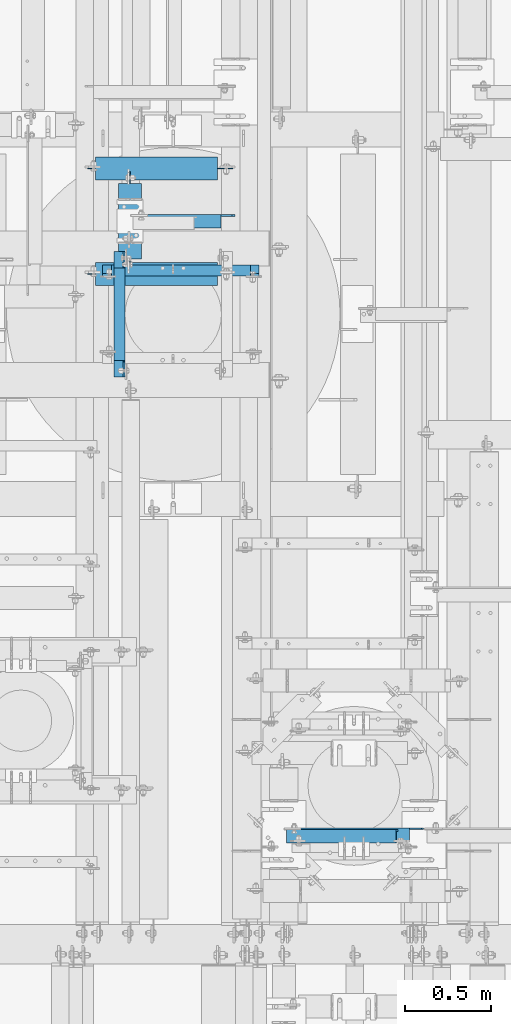
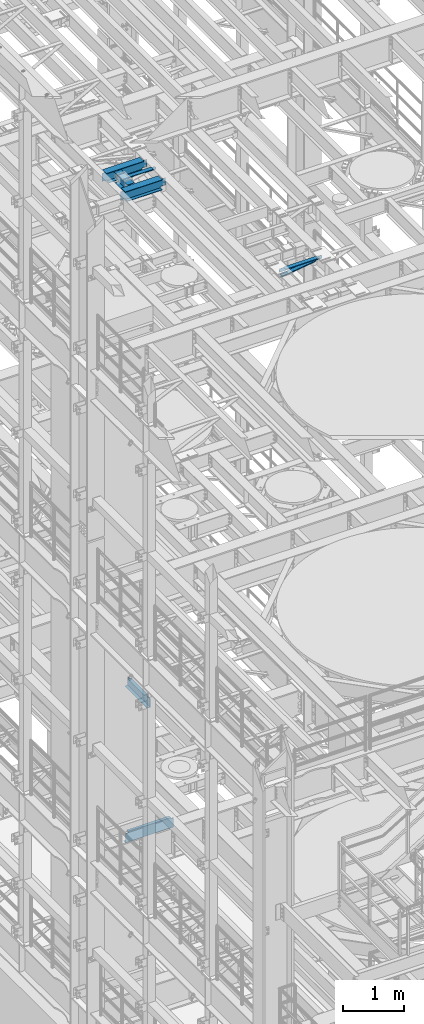
# One storey, part 1258 of 1876: 8 beams, 8 elements without a shape of their own.
"""IFC2X3 building model written with IfcOpenShell, lengths in millimetres."""

from ifc_helpers import new_model, si_unit, frame, origin_with_axes, place, context, subcontext, project, spatial, faceted_brep, material, type_object, element, aggregate, save


model = new_model("IFC2X3")

# Units and contexts
model_context = context("Model", 3, precision=1e-05, world=origin_with_axes())
body_context = subcontext(model_context, "Body", "Model", "MODEL_VIEW")
ifc_project = project(units=[si_unit("LENGTHUNIT", "METRE", prefix="MILLI"), si_unit("AREAUNIT", "SQUARE_METRE"), si_unit("VOLUMEUNIT", "CUBIC_METRE"), si_unit("MASSUNIT", "GRAM", prefix="KILO"), si_unit("TIMEUNIT", "SECOND"), si_unit("PLANEANGLEUNIT", "RADIAN"), si_unit("SOLIDANGLEUNIT", "STERADIAN"), si_unit("THERMODYNAMICTEMPERATUREUNIT", "DEGREE_CELSIUS"), si_unit("LUMINOUSINTENSITYUNIT", "LUMEN")], contexts=[model_context])

# Site, building, storey
site_placement = place(None, origin_with_axes())
site = spatial("IfcSite", under=ifc_project, at=site_placement, CompositionType="ELEMENT")
building_placement = place(site_placement, origin_with_axes())
building = spatial("IfcBuilding", under=site, at=building_placement, Name="Undefined", CompositionType="ELEMENT")
storey_placement = place(building_placement, origin_with_axes())
storey = spatial("IfcBuildingStorey", under=building, at=storey_placement, Name="Undefined", CompositionType="ELEMENT", Elevation=0.0)

# Assembly, beam
assembly_1_placement = place(storey_placement, origin_with_axes())
assembly_1 = element("IfcElementAssembly", 1, at=assembly_1_placement, inside=storey, AssemblyPlace="NOTDEFINED", PredefinedType="RIGID_FRAME")
ifc_material_1 = material(Name="STEEL/A36")
beam_type_1 = type_object("IfcBeamType", Name="L3X3X3/8", PredefinedType="NOTDEFINED")
beam_1_placement = place(assembly_1_placement, frame((4018.36120549084, 2149.47745692088, 17834.3261676342), z_axis=(0.0, -1.0, 0.0), x_axis=(0.990783001765335, -1.02999998879822e-07, 0.13545864096787)))
beam_1 = element("IfcBeam", 2, at=beam_1_placement, type_object=beam_type_1, material=ifc_material_1, ObjectType="L3X3X3/8", context=body_context, shape_type="Brep", body=[
    faceted_brep([(16.0226810146332, 38.0999999999585, -38.1000000000004), (16.0226810114837, 38.1000000000822, 38.1000000000004), (656.288881702969, 38.1000000006679, 38.0999999998849), (656.288881706117, 38.1000000005479, -38.1000000001154), (16.0226810114755, 28.5750000000808, 38.0999999999995), (656.28888170296, 28.5750000006665, 38.0999999998844), (16.0226810142303, 28.5749999999753, -28.5750000000012), (656.288881705715, 28.5750000005573, -28.5750000001158), (16.0226810141694, -38.1000000000386, -28.5750000000062), (656.288881705656, -38.0999999994565, -28.5750000001217), (16.0226810145641, -38.1000000000531, -38.1000000000063), (656.288881706049, -38.099999999471, -38.1000000001218)], [[[0, 1, 2, 3]], [[1, 4, 5, 2]], [[4, 6, 7, 5]], [[6, 8, 9, 7]], [[8, 10, 11, 9]], [[10, 0, 3, 11]], [[5, 7, 9, 11, 3, 2]], [[10, 8, 6, 4, 1, 0]]]),
])
aggregate(assembly_1, [beam_1])

assembly_2_placement = place(storey_placement, origin_with_axes())
assembly_2 = element("IfcElementAssembly", 3, at=assembly_2_placement, inside=storey, Name="ANGLE", AssemblyPlace="NOTDEFINED", PredefinedType="RIGID_FRAME")
beam_2_placement = place(assembly_2_placement, frame((4013.20024389053, 2159.00245745755, 17945.1), z_axis=(0.0, -1.0, 0.0), x_axis=(1.0, 0.0, 0.0)))
beam_2 = element("IfcBeam", 4, at=beam_2_placement, type_object=beam_type_1, material=ifc_material_1, Name="ANGLE", ObjectType="L3X3X3/8", context=body_context, shape_type="Brep", body=[
    faceted_brep([(728.662753137652, 28.5750000000007, -28.5750000001394), (728.662760071853, 28.5750000000007, 38.0999999998608), (84.1369379238226, 28.5750017223108, 38.099999999984), (84.1369309896222, 28.5750000000007, -28.5750000000166), (728.662385083913, 38.0999999999985, 38.0999999998608), (84.1373129237786, 38.0999999999985, 38.0999999999835), (15.8749292730308, 28.5750000000007, -28.5750000000035), (15.874928282431, 28.5750108662178, -38.1000000000035), (3.17492847316589, 15.8750110569526, -38.1000000000013), (3.17492946376569, 15.8750099139615, -28.5750000000012), (84.1369299990224, 28.5750108662141, -38.1000000000167), (84.1373049986182, 38.0999999999985, -38.1000000000167), (728.662377158752, 38.0999999999985, -38.1000000001395), (728.662752147051, 28.5750017223108, -38.1000000001395), (796.924754869784, 28.5750000000007, -28.5750000001522), (796.924753879185, 28.5750017223145, -38.1000000001522), (809.624754679051, 15.8750030560368, -28.5750000001544), (809.624753688451, 15.8750019130493, -38.1000000001545), (809.624754679051, 3.17500420044598, -28.5750000001544), (809.624753688451, 3.17500305745853, -38.1000000001545), (809.62475315317, -38.0999999999985, -28.5750000001549), (809.62475216257, -38.0999999999985, -38.100000000155), (3.17493098964678, -38.0999999999985, -28.5750000000012), (3.17492999904698, -38.0999999999985, -38.1000000000013), (3.17492847316589, 3.17501220136182, -38.1000000000013), (3.17492946376569, 3.17501105837073, -28.5750000000012)], [[[0, 1, 2, 3]], [[1, 4, 5, 2]], [[6, 7, 8, 9]], [[3, 10, 7, 6]], [[2, 5, 11, 10, 3]], [[4, 12, 11, 5]], [[1, 0, 13, 12, 4]], [[14, 15, 13, 0]], [[16, 17, 15, 14]], [[18, 19, 17, 16]], [[19, 18, 20, 21]], [[21, 20, 22, 23]], [[8, 7, 10, 11, 12, 13, 15, 17, 19, 21, 23, 24]], [[9, 8, 24, 25]], [[20, 18, 16, 14, 0, 3, 6, 9, 25, 22]], [[24, 23, 22, 25]]]),
])
aggregate(assembly_2, [beam_2])

assembly_3_placement = place(storey_placement, origin_with_axes())
assembly_3 = element("IfcElementAssembly", 5, at=assembly_3_placement, inside=storey, Name="ANGLE", AssemblyPlace="NOTDEFINED", PredefinedType="RIGID_FRAME")
beam_3_placement = place(assembly_3_placement, frame((3121.40552078944, 5715.01527389422, 17945.1), z_axis=(0.0, -1.0, 0.0), x_axis=(1.0, 0.0, 0.0)))
beam_3 = element("IfcBeam", 6, at=beam_3_placement, type_object=beam_type_1, material=ifc_material_1, Name="ANGLE", ObjectType="L3X3X3/8", context=body_context, shape_type="Brep", body=[
    faceted_brep([(528.257476155022, 28.5750000000007, -28.5749999999553), (528.257485356159, 28.5750000000007, 38.1000000000449), (68.2619997150068, 28.5750001907327, 38.0999999999999), (68.2619983148161, 28.5750000000007, -28.5749999999998), (528.257485356156, 38.0999999999985, 38.1000000000449), (68.2619997149695, 38.0999999999985, 38.0999999999999), (15.8749292730308, 28.5750000000007, -28.5750000000035), (15.874928282431, 28.5750108662178, -38.1000000000035), (3.17492847316589, 15.8750110569526, -38.1000000000013), (3.17492946376569, 15.8750099139615, -28.5750000000012), (68.2619981147891, 28.5750001907327, -38.0999999999999), (68.2619981147864, 38.0999999999985, -38.0999999999999), (528.257474840535, 38.0999999999985, -38.0999999999558), (528.257474840573, 28.5750001907363, -38.0999999999558), (590.169474903803, 28.5750000000007, -28.5749999999498), (590.169473589354, 28.5750001907363, -38.0999999999503), (609.219474140863, 9.52500095367577, -28.5749999999489), (609.219472826415, 9.52500095367577, -38.0999999999494), (609.219474140863, 3.17500152588036, -28.5749999999489), (609.219472826415, 3.17500152588036, -38.0999999999494), (609.219475768761, -38.0999999999985, -28.5749999999489), (609.219474616236, -38.0999999999985, -38.0999999999485), (3.17493098964678, -38.0999999999985, -28.5750000000012), (3.17492999904698, -38.0999999999985, -38.1000000000013), (3.17492847316589, 3.17501220136182, -38.1000000000013), (3.17492946376569, 3.17501105837073, -28.5750000000012)], [[[0, 1, 2, 3]], [[1, 4, 5, 2]], [[6, 7, 8, 9]], [[3, 10, 7, 6]], [[2, 5, 11, 10, 3]], [[4, 12, 11, 5]], [[1, 0, 13, 12, 4]], [[14, 15, 13, 0]], [[16, 17, 15, 14]], [[18, 19, 17, 16]], [[19, 18, 20, 21]], [[21, 20, 22, 23]], [[8, 7, 10, 11, 12, 13, 15, 17, 19, 21, 23, 24]], [[9, 8, 24, 25]], [[20, 18, 16, 14, 0, 3, 6, 9, 25, 22]], [[24, 23, 22, 25]]]),
])
aggregate(assembly_3, [beam_3])

assembly_4_placement = place(storey_placement, origin_with_axes())
assembly_4 = element("IfcElementAssembly", 7, at=assembly_4_placement, inside=storey, Name="BEAM", AssemblyPlace="NOTDEFINED", PredefinedType="RIGID_FRAME")
ifc_material_2 = material(Name="STEEL/A992")
beam_type_2 = type_object("IfcBeamType", Name="W8X18", PredefinedType="NOTDEFINED")
beam_4_placement = place(assembly_4_placement, frame((3121.40548423619, 5413.14856567383, 17880.0125), z_axis=(0.0, 0.0, 1.0), x_axis=(0.0, 1.0, 0.0)))
beam_4 = element("IfcBeam", 8, at=beam_4_placement, type_object=beam_type_2, material=ifc_material_2, Name="BEAM", ObjectType="W8X18", context=body_context, shape_type="Brep", body=[
    faceted_brep([(498.475, -3.17500000000018, -95.25), (498.475, -66.6750000000002, -95.25), (498.475, -66.6750000000002, -103.1875), (498.475, 66.6750000000002, -103.1875), (498.475, 66.6750000000002, -95.25), (498.475, 3.17500000000018, -95.25), (498.475, 3.17500000000018, -90.4874998092673), (498.475, -3.17500000000018, -90.4874998092673), (499.441729922588, 3.17500000000018, -85.6274202912209), (499.441729922588, -3.17500000000018, -85.6274202912209), (502.194743823066, 3.17500000000018, -81.5072438230673), (502.194743823066, -3.17500000000018, -81.5072438230673), (506.31492029122, 3.17500000000018, -78.7542299225897), (506.31492029122, -3.17500000000018, -78.7542299225897), (511.174999809266, 3.17500000000018, -77.7875000000022), (511.174999809266, -3.17500000000018, -77.7875000000022), (590.550000000001, -3.17500000000018, -77.7875000000022), (590.550000000001, 3.17500000000018, -77.7875000000022), (82.5500000000011, 3.17500000000018, 95.25), (82.5500000000011, 66.6750000000002, 95.25), (520.7, 66.6750000000002, 95.25), (520.7, 3.17500000000018, 95.25), (104.775000000001, -3.17500000000018, -90.4874998092673), (104.775000000001, 3.17500000000018, -90.4874998092673), (104.775000000001, 3.17500000000018, -95.25), (104.775000000001, 66.6750000000002, -95.25), (104.775000000001, 66.6750000000002, -103.1875), (104.775000000001, -66.6750000000002, -103.1875), (104.775000000001, -66.6750000000002, -95.25), (104.775000000001, -3.17500000000018, -95.25), (103.808270077413, -3.17500000000018, -85.6274202912209), (103.808270077413, 3.17500000000018, -85.6274202912209), (101.055256176935, -3.17500000000018, -81.5072438230673), (101.055256176935, 3.17500000000018, -81.5072438230673), (96.9350797087809, -3.17500000000018, -78.7542299225897), (96.9350797087809, 3.17500000000018, -78.7542299225897), (92.0750001907354, -3.17500000000018, -77.7875000000022), (92.0750001907354, 3.17500000000018, -77.7875000000022), (12.7000000000007, -3.17500000000018, -77.7875000000022), (12.7000000000007, 3.17500000000018, -77.7875000000022), (12.7000000000007, -3.17500000000018, 77.7874999999985), (12.7000000000007, 3.17500000000018, 77.7874999999985), (69.850000190736, -3.17500000000018, 77.7874999999985), (69.850000190736, 3.17500000000018, 77.7874999999985), (74.7100797087814, -3.17500000000018, 78.7542299225861), (74.7100797087814, 3.17500000000018, 78.7542299225861), (78.8302561769351, -3.17500000000018, 81.5072438230636), (78.8302561769351, 3.17500000000018, 81.5072438230636), (81.5832700774135, -3.17500000000018, 85.6274202912173), (81.5832700774135, 3.17500000000018, 85.6274202912173), (82.5500000000011, -3.17500000000018, 90.4874998092637), (82.5500000000011, 3.17500000000018, 90.4874998092637), (82.5500000000011, -66.6750000000002, 103.1875), (82.5500000000011, 66.6750000000002, 103.1875), (82.5500000000011, -3.17500000000018, 95.25), (82.5500000000011, -66.6750000000002, 95.25), (520.7, -3.17500000000018, 95.25), (520.7, -66.6750000000002, 95.25), (520.7, -66.6750000000002, 103.1875), (520.7, 66.6750000000002, 103.1875), (520.7, -3.17500000000018, 90.4874998092637), (520.7, 3.17500000000018, 90.4874998092637), (521.666729922587, -3.17500000000018, 85.6274202912173), (521.666729922587, 3.17500000000018, 85.6274202912173), (524.419743823066, -3.17500000000018, 81.5072438230636), (524.419743823066, 3.17500000000018, 81.5072438230636), (528.539920291219, -3.17500000000018, 78.7542299225861), (528.539920291219, 3.17500000000018, 78.7542299225861), (533.399999809265, -3.17500000000018, 77.7874999999985), (533.399999809265, 3.17500000000018, 77.7874999999985), (590.550000000001, -3.17500000000018, 77.7874999999985), (590.550000000001, 3.17500000000018, 77.7874999999985)], [[[0, 1, 2, 3, 4, 5, 6, 7]], [[7, 6, 8, 9]], [[9, 8, 10, 11]], [[11, 10, 12, 13]], [[13, 12, 14, 15]], [[16, 15, 14, 17]], [[18, 19, 20, 21]], [[22, 23, 24, 25, 26, 27, 28, 29]], [[30, 31, 23, 22]], [[32, 33, 31, 30]], [[34, 35, 33, 32]], [[36, 37, 35, 34]], [[38, 39, 37, 36]], [[40, 41, 39, 38]], [[42, 43, 41, 40]], [[44, 45, 43, 42]], [[46, 47, 45, 44]], [[48, 49, 47, 46]], [[50, 51, 49, 48]], [[52, 53, 19, 18, 51, 50, 54, 55]], [[55, 54, 56, 57]], [[52, 55, 57, 58]], [[53, 52, 58, 59]], [[19, 53, 59, 20]], [[58, 57, 56, 60, 61, 21, 20, 59]], [[62, 63, 61, 60]], [[64, 65, 63, 62]], [[66, 67, 65, 64]], [[68, 69, 67, 66]], [[70, 71, 69, 68]], [[71, 70, 16, 17]], [[12, 10, 8, 6, 5, 24, 23, 31, 33, 35, 37, 39, 41, 43, 45, 47, 49, 51, 18, 21, 61, 63, 65, 67, 69, 71, 17, 14]], [[25, 24, 5, 4]], [[26, 25, 4, 3]], [[27, 26, 3, 2]], [[28, 27, 2, 1]], [[29, 28, 1, 0]], [[70, 68, 66, 64, 62, 60, 56, 54, 50, 48, 46, 44, 42, 40, 38, 36, 34, 32, 30, 22, 29, 0, 7, 9, 11, 13, 15, 16]]]),
])
aggregate(assembly_4, [beam_4])

assembly_5_placement = place(storey_placement, origin_with_axes())
assembly_5 = element("IfcElementAssembly", 9, at=assembly_5_placement, inside=storey, Name="BEAM", AssemblyPlace="NOTDEFINED", PredefinedType="RIGID_FRAME")
beam_5_placement = place(assembly_5_placement, frame((2857.5, 6019.57356567383, 17880.0125), z_axis=(0.0, 0.0, 1.0), x_axis=(1.0, 0.0, 0.0)))
beam_5 = element("IfcBeam", 10, at=beam_5_placement, type_object=beam_type_2, material=ifc_material_2, Name="BEAM", ObjectType="W8X18", context=body_context, shape_type="Brep", body=[
    faceted_brep([(771.525000000001, -3.17500000000018, -95.25), (771.525000000001, -66.6750000000002, -95.25), (771.525000000001, -66.6750000000002, -103.1875), (771.525000000001, 66.6750000000002, -103.1875), (771.525000000001, 66.6750000000002, -95.25), (771.525000000001, 3.17500000000018, -95.25), (771.525000000001, 3.17500000000018, -84.1374998092651), (771.525000000001, -3.17500000000018, -84.1374998092651), (772.491729922589, 3.17500000000018, -79.2774202912187), (772.491729922589, -3.17500000000018, -79.2774202912187), (775.244743823067, 3.17500000000018, -75.1572438230651), (775.244743823067, -3.17500000000018, -75.1572438230651), (779.36492029122, 3.17500000000018, -72.4042299225875), (779.36492029122, -3.17500000000018, -72.4042299225875), (784.224999809266, 3.17500000000018, -71.4375), (784.224999809266, -3.17500000000018, -71.4375), (860.425, -3.17500000000018, -71.4375), (860.425, 3.17500000000018, -71.4375), (63.5000000000009, -66.6750000000002, 103.1875), (63.5000000000009, 66.6750000000002, 103.1875), (63.5000000000009, 66.6750000000002, 96.8374998092695), (63.5000000000009, -66.6750000000002, 96.8374998092695), (63.1842266547242, 3.17500000000018, 95.25), (63.1842266547242, 66.6750000000002, 95.25), (771.525000000001, 66.6750000000002, 95.25), (771.525000000001, 3.17500000000018, 95.25), (107.950000000001, -3.17500000000018, -90.48749980926), (107.950000000001, 3.17500000000018, -90.48749980926), (107.950000000001, 3.17500000000018, -95.25), (107.950000000001, 66.6750000000002, -95.25), (107.950000000001, 66.6750000000002, -103.1875), (107.950000000001, -66.6750000000002, -103.1875), (107.950000000001, -66.6750000000002, -95.25), (107.950000000001, -3.17500000000018, -95.25), (106.983270077413, -3.17500000000018, -85.6274202912136), (106.983270077413, 3.17500000000018, -85.6274202912136), (104.230256176935, -3.17500000000018, -81.50724382306), (104.230256176935, 3.17500000000018, -81.50724382306), (100.110079708781, -3.17500000000018, -78.7542299225825), (100.110079708781, 3.17500000000018, -78.7542299225825), (95.2500001907356, -3.17500000000018, -77.7874999999949), (95.2500001907356, 3.17500000000018, -77.7874999999949), (15.875, -3.17500000000018, -77.7874999999949), (15.875, 3.17500000000018, -77.7874999999949), (15.875, -3.17500000000018, 84.1375000000044), (15.875, 3.17500000000018, 84.1375000000044), (50.8000001907358, -3.17500000000018, 84.1375000000044), (50.8000001907358, 3.17500000000018, 84.1375000000044), (55.6600797087813, -3.17500000000018, 85.1042299225919), (55.6600797087813, 3.17500000000018, 85.1042299225919), (59.7802561769349, -3.17500000000018, 87.8572438230694), (59.7802561769349, 3.17500000000018, 87.8572438230694), (62.5332700774129, -3.17500000000018, 91.9774202912231), (62.5332700774129, 3.17500000000018, 91.9774202912231), (63.1842266547242, -3.17500000000018, 95.25), (63.1842266547242, -66.6750000000002, 95.25), (771.525000000001, -3.17500000000018, 95.25), (771.525000000001, -66.6750000000002, 95.25), (771.525000000001, -66.6750000000002, 103.1875), (771.525000000001, 66.6750000000002, 103.1875), (771.525000000001, -3.17500000000018, 84.1374998092651), (771.525000000001, 3.17500000000018, 84.1374998092651), (772.491729922588, -3.17500000000018, 79.2774202912187), (772.491729922588, 3.17500000000018, 79.2774202912187), (775.244743823067, -3.17500000000018, 75.1572438230651), (775.244743823067, 3.17500000000018, 75.1572438230651), (779.36492029122, -3.17500000000018, 72.4042299225875), (779.36492029122, 3.17500000000018, 72.4042299225875), (784.224999809266, -3.17500000000018, 71.4375), (784.224999809266, 3.17500000000018, 71.4375), (860.425, -3.17500000000018, 71.4375), (860.425, 3.17500000000018, 71.4375)], [[[0, 1, 2, 3, 4, 5, 6, 7]], [[7, 6, 8, 9]], [[9, 8, 10, 11]], [[11, 10, 12, 13]], [[13, 12, 14, 15]], [[16, 15, 14, 17]], [[18, 19, 20, 21]], [[22, 23, 24, 25]], [[26, 27, 28, 29, 30, 31, 32, 33]], [[34, 35, 27, 26]], [[36, 37, 35, 34]], [[38, 39, 37, 36]], [[40, 41, 39, 38]], [[42, 43, 41, 40]], [[44, 45, 43, 42]], [[46, 47, 45, 44]], [[48, 49, 47, 46]], [[50, 51, 49, 48]], [[52, 53, 51, 50]], [[21, 20, 23, 22, 53, 52, 54, 55]], [[55, 54, 56, 57]], [[18, 21, 55, 57, 58]], [[19, 18, 58, 59]], [[23, 20, 19, 59, 24]], [[58, 57, 56, 60, 61, 25, 24, 59]], [[62, 63, 61, 60]], [[64, 65, 63, 62]], [[66, 67, 65, 64]], [[68, 69, 67, 66]], [[70, 71, 69, 68]], [[71, 70, 16, 17]], [[12, 10, 8, 6, 5, 28, 27, 35, 37, 39, 41, 43, 45, 47, 49, 51, 53, 22, 25, 61, 63, 65, 67, 69, 71, 17, 14]], [[29, 28, 5, 4]], [[30, 29, 4, 3]], [[31, 30, 3, 2]], [[32, 31, 2, 1]], [[33, 32, 1, 0]], [[70, 68, 66, 64, 62, 60, 56, 54, 52, 50, 48, 46, 44, 42, 40, 38, 36, 34, 26, 33, 0, 7, 9, 11, 13, 15, 16]]]),
])
aggregate(assembly_5, [beam_5])

assembly_6_placement = place(storey_placement, origin_with_axes())
assembly_6 = element("IfcElementAssembly", 11, at=assembly_6_placement, inside=storey, Name="BEAM", AssemblyPlace="NOTDEFINED", PredefinedType="RIGID_FRAME")
beam_6_placement = place(assembly_6_placement, frame((2857.5, 5409.97356567383, 17880.0125), z_axis=(0.0, 0.0, 1.0), x_axis=(1.0, 0.0, 0.0)))
beam_6 = element("IfcBeam", 12, at=beam_6_placement, type_object=beam_type_2, material=ifc_material_2, Name="BEAM", ObjectType="W8X18", context=body_context, shape_type="Brep", body=[
    faceted_brep([(771.525000000001, -3.17500000000018, -95.25), (771.525000000001, -66.6750000000002, -95.25), (771.525000000001, -66.6750000000002, -103.1875), (771.525000000001, 66.6750000000002, -103.1875), (771.525000000001, 66.6750000000002, -95.25), (771.525000000001, 3.17500000000018, -95.25), (771.525000000001, 3.17500000000018, -84.1374998092651), (771.525000000001, -3.17500000000018, -84.1374998092651), (772.491729922589, 3.17500000000018, -79.2774202912187), (772.491729922589, -3.17500000000018, -79.2774202912187), (775.244743823067, 3.17500000000018, -75.1572438230651), (775.244743823067, -3.17500000000018, -75.1572438230651), (779.36492029122, 3.17500000000018, -72.4042299225875), (779.36492029122, -3.17500000000018, -72.4042299225875), (784.224999809266, 3.17500000000018, -71.4375), (784.224999809266, -3.17500000000018, -71.4375), (860.425, -3.17500000000018, -71.4375), (860.425, 3.17500000000018, -71.4375), (63.5000000000009, -66.6750000000002, 103.1875), (63.5000000000009, 66.6750000000002, 103.1875), (63.5000000000009, 66.6750000000002, 96.8374998092695), (63.5000000000009, -66.6750000000002, 96.8374998092695), (63.1842266547242, 3.17500000000018, 95.25), (63.1842266547242, 66.6750000000002, 95.25), (771.525000000001, 66.6750000000002, 95.25), (771.525000000001, 3.17500000000018, 95.25), (107.950000000001, -3.17500000000018, -90.48749980926), (107.950000000001, 3.17500000000018, -90.48749980926), (107.950000000001, 3.17500000000018, -95.25), (107.950000000001, 66.6750000000002, -95.25), (107.950000000001, 66.6750000000002, -103.1875), (107.950000000001, -66.6750000000002, -103.1875), (107.950000000001, -66.6750000000002, -95.25), (107.950000000001, -3.17500000000018, -95.25), (106.983270077413, -3.17500000000018, -85.6274202912136), (106.983270077413, 3.17500000000018, -85.6274202912136), (104.230256176935, -3.17500000000018, -81.50724382306), (104.230256176935, 3.17500000000018, -81.50724382306), (100.110079708781, -3.17500000000018, -78.7542299225825), (100.110079708781, 3.17500000000018, -78.7542299225825), (95.2500001907356, -3.17500000000018, -77.7874999999949), (95.2500001907356, 3.17500000000018, -77.7874999999949), (15.875, -3.17500000000018, -77.7874999999949), (15.875, 3.17500000000018, -77.7874999999949), (15.875, -3.17500000000018, 84.1375000000044), (15.875, 3.17500000000018, 84.1375000000044), (50.8000001907358, -3.17500000000018, 84.1375000000044), (50.8000001907358, 3.17500000000018, 84.1375000000044), (55.6600797087813, -3.17500000000018, 85.1042299225919), (55.6600797087813, 3.17500000000018, 85.1042299225919), (59.7802561769349, -3.17500000000018, 87.8572438230694), (59.7802561769349, 3.17500000000018, 87.8572438230694), (62.5332700774129, -3.17500000000018, 91.9774202912231), (62.5332700774129, 3.17500000000018, 91.9774202912231), (63.1842266547242, -3.17500000000018, 95.25), (63.1842266547242, -66.6750000000002, 95.25), (771.525000000001, -3.17500000000018, 95.25), (771.525000000001, -66.6750000000002, 95.25), (771.525000000001, -66.6750000000002, 103.1875), (771.525000000001, 66.6750000000002, 103.1875), (771.525000000001, -3.17500000000018, 84.1374998092651), (771.525000000001, 3.17500000000018, 84.1374998092651), (772.491729922588, -3.17500000000018, 79.2774202912187), (772.491729922588, 3.17500000000018, 79.2774202912187), (775.244743823067, -3.17500000000018, 75.1572438230651), (775.244743823067, 3.17500000000018, 75.1572438230651), (779.36492029122, -3.17500000000018, 72.4042299225875), (779.36492029122, 3.17500000000018, 72.4042299225875), (784.224999809266, -3.17500000000018, 71.4375), (784.224999809266, 3.17500000000018, 71.4375), (860.425, -3.17500000000018, 71.4375), (860.425, 3.17500000000018, 71.4375)], [[[0, 1, 2, 3, 4, 5, 6, 7]], [[7, 6, 8, 9]], [[9, 8, 10, 11]], [[11, 10, 12, 13]], [[13, 12, 14, 15]], [[16, 15, 14, 17]], [[18, 19, 20, 21]], [[22, 23, 24, 25]], [[26, 27, 28, 29, 30, 31, 32, 33]], [[34, 35, 27, 26]], [[36, 37, 35, 34]], [[38, 39, 37, 36]], [[40, 41, 39, 38]], [[42, 43, 41, 40]], [[44, 45, 43, 42]], [[46, 47, 45, 44]], [[48, 49, 47, 46]], [[50, 51, 49, 48]], [[52, 53, 51, 50]], [[21, 20, 23, 22, 53, 52, 54, 55]], [[55, 54, 56, 57]], [[18, 21, 55, 57, 58]], [[19, 18, 58, 59]], [[23, 20, 19, 59, 24]], [[58, 57, 56, 60, 61, 25, 24, 59]], [[62, 63, 61, 60]], [[64, 65, 63, 62]], [[66, 67, 65, 64]], [[68, 69, 67, 66]], [[70, 71, 69, 68]], [[71, 70, 16, 17]], [[12, 10, 8, 6, 5, 28, 27, 35, 37, 39, 41, 43, 45, 47, 49, 51, 53, 22, 25, 61, 63, 65, 67, 69, 71, 17, 14]], [[29, 28, 5, 4]], [[30, 29, 4, 3]], [[31, 30, 3, 2]], [[32, 31, 2, 1]], [[33, 32, 1, 0]], [[70, 68, 66, 64, 62, 60, 56, 54, 52, 50, 48, 46, 44, 42, 40, 38, 36, 34, 26, 33, 0, 7, 9, 11, 13, 15, 16]]]),
])
aggregate(assembly_6, [beam_6])

assembly_7_placement = place(storey_placement, origin_with_axes())
assembly_7 = element("IfcElementAssembly", 13, at=assembly_7_placement, inside=storey, Name="BEAM", AssemblyPlace="NOTDEFINED", PredefinedType="RIGID_FRAME")
beam_type_3 = type_object("IfcBeamType", Name="C8X18.75", PredefinedType="NOTDEFINED")
beam_7_placement = place(assembly_7_placement, frame((3060.7, 5556.25, 8051.8), z_axis=(0.0, 0.0, 1.0), x_axis=(0.0, -1.0, 0.0)))
beam_7 = element("IfcBeam", 14, at=beam_7_placement, type_object=beam_type_3, material=ifc_material_1, Name="BEAM", ObjectType="C8X18.75", context=body_context, shape_type="Brep", body=[
    faceted_brep([(648.493749999994, -31.75, 101.6), (648.493749999994, -31.75, 97.3645500000002), (648.493749999994, 19.0500000000002, 88.9012700000003), (648.493749999994, 19.0500000000002, 82.5499998092655), (648.493749999994, 31.75, 82.5499998092655), (648.493749999994, 31.75, 101.6), (649.460479922582, 19.0500000000002, 77.68992029122), (649.460479922582, 31.75, 77.68992029122), (652.21349382306, 19.0500000000002, 73.5697438230663), (652.21349382306, 31.75, 73.5697438230663), (656.333670291214, 19.0500000000002, 70.8167299225879), (656.333670291214, 31.75, 70.8167299225879), (661.193749809259, 19.0500000000002, 69.8500000000004), (661.193749809259, 31.75, 69.8500000000004), (745.331249999993, 19.0500000000002, 69.8500000000004), (745.331249999993, 31.75, 69.8500000000004), (113.50625, -31.75, 101.6), (113.50625, 31.75, 101.6), (113.50625, 31.75, 82.5499998092655), (113.50625, 19.0500000000002, 82.5499998092655), (113.50625, 19.0500000000002, 88.9012700000003), (113.50625, -31.75, 97.3645500000002), (112.539520077413, 31.75, 77.68992029122), (112.539520077413, 19.0500000000002, 77.68992029122), (109.786506176934, 31.75, 73.5697438230663), (109.786506176934, 19.0500000000002, 73.5697438230663), (105.666329708781, 31.75, 70.8167299225879), (105.666329708781, 19.0500000000002, 70.8167299225879), (100.806250190735, 31.75, 69.8500000000004), (100.806250190735, 19.0500000000002, 69.8500000000004), (16.6687499999998, 31.75, 69.8500000000004), (16.6687499999998, 19.0500000000002, 69.8500000000004), (16.6687499999998, 31.75, -101.6), (16.6687499999998, -31.75, -101.6), (16.6687499999998, -31.75, -97.3645500000002), (16.6687499999998, 19.0500000000002, -88.9012700000003), (745.331249999993, 31.75, -101.6), (745.331249999993, -31.75, -101.6), (745.331249999993, -31.75, -97.3645500000002), (745.331249999993, 19.0500000000002, -88.9012700000003)], [[[0, 1, 2, 3, 4, 5]], [[6, 7, 4, 3]], [[8, 9, 7, 6]], [[10, 11, 9, 8]], [[12, 13, 11, 10]], [[14, 15, 13, 12]], [[16, 17, 18, 19, 20, 21]], [[19, 18, 22, 23]], [[23, 22, 24, 25]], [[25, 24, 26, 27]], [[27, 26, 28, 29]], [[29, 28, 30, 31]], [[32, 33, 34, 35, 31, 30]], [[33, 32, 36, 37]], [[34, 33, 37, 38]], [[35, 34, 38, 39]], [[10, 8, 6, 3, 2, 20, 19, 23, 25, 27, 29, 31, 35, 39, 14, 12]], [[21, 20, 2, 1]], [[16, 21, 1, 0]], [[17, 16, 0, 5]], [[36, 32, 30, 28, 26, 24, 22, 18, 17, 5, 4, 7, 9, 11, 13, 15]], [[39, 38, 37, 36, 15, 14]]]),
])
aggregate(assembly_7, [beam_7])

assembly_8_placement = place(storey_placement, origin_with_axes())
assembly_8 = element("IfcElementAssembly", 15, at=assembly_8_placement, inside=storey, Name="BEAM", AssemblyPlace="NOTDEFINED", PredefinedType="RIGID_FRAME")
beam_8_placement = place(assembly_8_placement, frame((2895.6, 5429.99845581055, 5029.2), z_axis=(0.0, 0.0, -1.0), x_axis=(1.0, 0.0, 0.0)))
beam_8 = element("IfcBeam", 16, at=beam_8_placement, type_object=beam_type_3, material=ifc_material_1, Name="BEAM", ObjectType="C8X18.75", context=body_context, shape_type="Brep", body=[
    faceted_brep([(923.925, -31.75, -97.3645500000002), (923.925, -31.75, -101.6), (923.925, 31.75, -101.6), (923.925, 31.75, -95.2499998092644), (923.925, -19.0576219043478, -95.2499998092644), (924.891729922588, 31.75, -90.3899202912189), (924.891729922588, 10.1145240623118, -90.3899202912189), (925.886414246513, 19.0500000000002, -88.9012700000003), (927.644743823066, 31.75, -86.2697438230653), (927.644743823066, 19.0500000000002, -86.2697438230653), (931.76492029122, 31.75, -83.5167299225868), (931.76492029122, 19.0500000000002, -83.5167299225868), (936.624999809265, 31.75, -82.5499999999993), (936.624999809265, 19.0500000000002, -82.5499999999993), (974.725, 19.0500000000002, -82.5499999999993), (974.725, 31.75, -82.5499999999993), (66.6750000000002, -31.75, 101.599999999999), (66.6750000000002, -31.75, 97.3645499999984), (974.725, -31.75, 97.3645500000002), (974.725, -31.75, 101.6), (66.6750000000002, 31.75, 101.599999999999), (974.725, 31.75, 101.6), (117.475000000002, -19.0576219043487, -95.2499998092644), (117.475000000002, 31.75, -95.2499998092644), (117.475000000002, 31.75, -101.6), (117.475000000002, -31.75, -101.6), (117.475000000002, -31.75, -97.3645500000002), (116.508270077414, 10.1145240623118, -90.3899202912189), (116.508270077414, 31.75, -90.3899202912189), (115.51358575349, 19.0500000000002, -88.9012700000003), (113.755256176936, 19.0500000000002, -86.2697438230653), (113.755256176936, 31.75, -86.2697438230653), (109.635079708783, 19.0500000000002, -83.5167299225868), (109.635079708783, 31.75, -83.5167299225868), (104.775000190737, 19.0500000000002, -82.5499999999993), (104.775000190737, 31.75, -82.5499999999993), (66.675000000002, 19.0500000000002, -82.5499999999993), (66.675000000002, 31.75, -82.5499999999993), (66.675000000002, 19.0500000000002, 88.9012700000003), (974.725, 19.0500000000002, 88.9012700000003)], [[[0, 1, 2, 3, 4]], [[4, 3, 5, 6]], [[7, 6, 5, 8, 9]], [[9, 8, 10, 11]], [[11, 10, 12, 13]], [[14, 13, 12, 15]], [[16, 17, 18, 19]], [[20, 16, 19, 21]], [[22, 23, 24, 25, 26]], [[27, 28, 23, 22]], [[29, 30, 31, 28, 27]], [[32, 33, 31, 30]], [[34, 35, 33, 32]], [[36, 37, 35, 34]], [[38, 17, 16, 20, 37, 36]], [[17, 38, 39, 18]], [[21, 19, 18, 39, 14, 15]], [[10, 8, 5, 3, 2, 24, 23, 28, 31, 33, 35, 37, 20, 21, 15, 12]], [[25, 24, 2, 1]], [[26, 25, 1, 0]], [[29, 27, 22, 26, 0, 4, 6, 7]], [[39, 38, 36, 34, 32, 30, 29, 7, 9, 11, 13, 14]]]),
])
aggregate(assembly_8, [beam_8])

save(model, "model.ifc")
